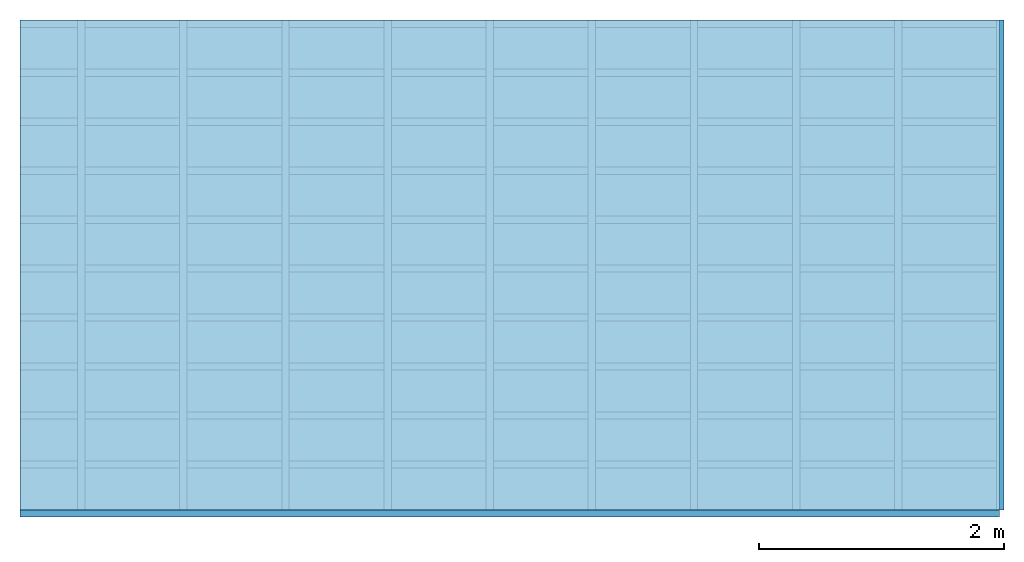
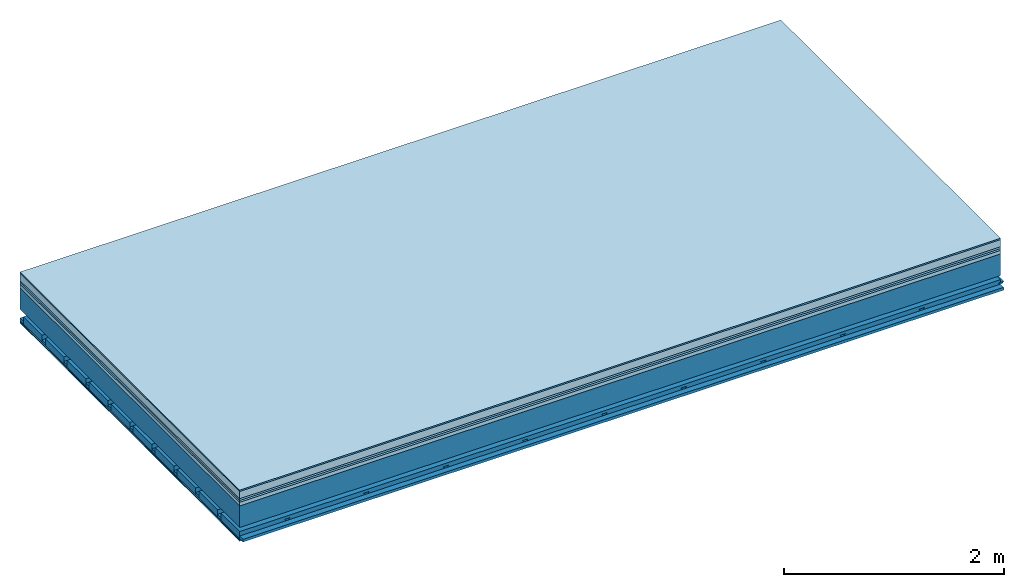
# One storey: 8 plates, 4 members, 1 element without a shape of its own.
"""IFC4 building model written with IfcOpenShell, lengths in metres."""

from ifc_helpers import new_model, si_unit, derived_unit, direction, frame, frame_2d, origin, origin_with_axes, place, context, project, spatial, polyline, rectangle, outline, extrude, material, layer, layer_set, type_object, element, aggregate, save


model = new_model("IFC4")

# Units and contexts
plan_context = context("Plan", 3, precision=1e-05, world=origin(), true_north=direction((0.0, 1.0)))
model_context = context("Model", 3, precision=1e-05, world=origin(), true_north=direction((0.0, 1.0)))
ifc_project = project(units=[si_unit("LENGTHUNIT", "METRE"), derived_unit("SOUNDPRESSUREUNIT", [(si_unit("PRESSUREUNIT", "PASCAL", prefix="MICRO"), 0)]), si_unit("ENERGYUNIT", "JOULE", prefix="MEGA"), si_unit("MASSUNIT", "GRAM", prefix="KILO"), derived_unit("THERMALTRANSMITTANCEUNIT", [(si_unit("POWERUNIT", "WATT"), 1), (si_unit("AREAUNIT", "SQUARE_METRE"), -1), (si_unit("THERMODYNAMICTEMPERATUREUNIT", "KELVIN"), -1)]), derived_unit("AREADENSITYUNIT", [(si_unit("MASSUNIT", "GRAM", prefix="KILO"), 1), (si_unit("AREAUNIT", "SQUARE_METRE"), -1)]), derived_unit("USERDEFINED", [(si_unit("ENERGYUNIT", "JOULE", prefix="MEGA"), 1), (si_unit("AREAUNIT", "SQUARE_METRE"), -1)])], contexts=[plan_context, model_context])

# Site, building, storey
site = spatial("IfcSite", under=ifc_project)
building_placement = place(None, origin())
building = spatial("IfcBuilding", under=site, at=building_placement)
storey_placement = place(building_placement, origin())
storey = spatial("IfcBuildingStorey", under=building, at=storey_placement)

# Slab, members, plates
ifc_material_1 = material(Category="11.013")
ifc_layer_1 = layer(ifc_material_1, 0.015, Name="Flooring")
ifc_material_2 = material(Name="Cement screed", Category="04.006")
ifc_layer_2 = layer(ifc_material_2, 0.08, Name="On-material")
ifc_material_3 = material(Name="Wood fiber generic product", Category="10.009")
ifc_layer_3 = layer(ifc_material_3, 0.02, Name="Impact sound insulation")
ifc_material_4 = material(Category="10.004")
ifc_layer_4 = layer(ifc_material_4, 0.02, Name="Additional insulation")
ifc_material_5 = material(Name="Garden plates", Category="02.007")
ifc_layer_5 = layer(ifc_material_5, 0.04, Name="on Supporting structure")
ifc_material_6 = material(Name="no composite action")
ifc_layer_6 = layer(ifc_material_6, 0.0, Name="Bond")
ifc_layer_7 = layer(None, 0.24, Name="Supporting structure")
ifc_layer_8 = layer(ifc_material_6, 0.0, Name="Bond")
ifc_layer_9 = layer(None, 0.095, Name="Coupling")
ifc_layer_10 = layer(None, 0.03, Name="Battens / profiles")
ifc_material_7 = material(Name="Plasterboard type A", Category="03.008")
ifc_layer_11 = layer(ifc_material_7, 0.0125, Name="Ceiling covering 1st layer")
ifc_layer_12 = layer(ifc_material_7, 0.0125, Name="Ceiling covering layer 2")
ifc_material_8 = material(Category="04.001")
ifc_layer_13 = layer(ifc_material_8, 0.003, Name="Surface / treatment")
ifc_layer_set = layer_set([ifc_layer_1, ifc_layer_2, ifc_layer_3, ifc_layer_4, ifc_layer_5, ifc_layer_6, ifc_layer_7, ifc_layer_8, ifc_layer_9, ifc_layer_10, ifc_layer_11, ifc_layer_12, ifc_layer_13])
slab_type = type_object("IfcSlabType", Name="A2174", PredefinedType="NOTDEFINED", material=ifc_layer_set)
slab_placement = place(None, frame((0.0, 0.0, 0.0), z_axis=(0.0, 0.0, -1.0), x_axis=(1.0, 0.0, 0.0)))
slab = element("IfcSlab", 1, at=slab_placement, inside=storey, type_object=slab_type, material=ifc_layer_set, Name="Slab #1")
ifc_material_9 = material(Name="Solid timber panel")
member_1_placement = place(slab_placement, origin())
member_1 = element("IfcMember", 2, at=member_1_placement, material=ifc_material_9, Name="Supporting structure", context=plan_context, shape_type="SweptSolid", body=[
    extrude(rectangle(XDim=1.0, YDim=0.24, at=frame_2d((0.5, 0.12), x_axis=(1.0, 0.0))), frame((0.0, 4.0, 0.175), z_axis=(0.0, -1.0, 0.0), x_axis=(1.0, 0.0, 0.0)), (0.0, 0.0, 1.0), 4.0),
    extrude(rectangle(XDim=1.0, YDim=0.24, at=frame_2d((0.5, 0.12), x_axis=(1.0, 0.0))), frame((1.0, 4.0, 0.175), z_axis=(0.0, -1.0, 0.0), x_axis=(1.0, 0.0, 0.0)), (0.0, 0.0, 1.0), 4.0),
    extrude(rectangle(XDim=1.0, YDim=0.24, at=frame_2d((0.5, 0.12), x_axis=(1.0, 0.0))), frame((2.0, 4.0, 0.175), z_axis=(0.0, -1.0, 0.0), x_axis=(1.0, 0.0, 0.0)), (0.0, 0.0, 1.0), 4.0),
    extrude(rectangle(XDim=1.0, YDim=0.24, at=frame_2d((0.5, 0.12), x_axis=(1.0, 0.0))), frame((3.0, 4.0, 0.175), z_axis=(0.0, -1.0, 0.0), x_axis=(1.0, 0.0, 0.0)), (0.0, 0.0, 1.0), 4.0),
    extrude(rectangle(XDim=1.0, YDim=0.24, at=frame_2d((0.5, 0.12), x_axis=(1.0, 0.0))), frame((4.0, 4.0, 0.175), z_axis=(0.0, -1.0, 0.0), x_axis=(1.0, 0.0, 0.0)), (0.0, 0.0, 1.0), 4.0),
    extrude(rectangle(XDim=1.0, YDim=0.24, at=frame_2d((0.5, 0.12), x_axis=(1.0, 0.0))), frame((5.0, 4.0, 0.175), z_axis=(0.0, -1.0, 0.0), x_axis=(1.0, 0.0, 0.0)), (0.0, 0.0, 1.0), 4.0),
    extrude(rectangle(XDim=1.0, YDim=0.24, at=frame_2d((0.5, 0.12), x_axis=(1.0, 0.0))), frame((6.0, 4.0, 0.175), z_axis=(0.0, -1.0, 0.0), x_axis=(1.0, 0.0, 0.0)), (0.0, 0.0, 1.0), 4.0),
    extrude(rectangle(XDim=1.0, YDim=0.24, at=frame_2d((0.5, 0.12), x_axis=(1.0, 0.0))), frame((7.0, 4.0, 0.175), z_axis=(0.0, -1.0, 0.0), x_axis=(1.0, 0.0, 0.0)), (0.0, 0.0, 1.0), 4.0),
])
ifc_material_10 = material()
member_2_placement = place(slab_placement, origin())
member_2 = element("IfcMember", 3, at=member_2_placement, material=ifc_material_10, Name="Coupling", context=plan_context, shape_type="SweptSolid", body=[
    extrude(outline(polyline([(0.0, 0.0), (0.06, 0.0), (0.04, 0.02), (0.02, 0.02), (0.0, 0.0)])), frame((0.47, 4.0, 0.49), z_axis=(0.0, -1.0, 0.0), x_axis=(1.0, 0.0, 0.0)), (0.0, 0.0, 1.0), 4.0),
    extrude(outline(polyline([(0.0, 0.0), (0.06, 0.0), (0.04, 0.02), (0.02, 0.02), (0.0, 0.0)])), frame((1.304, 4.0, 0.49), z_axis=(0.0, -1.0, 0.0), x_axis=(1.0, 0.0, 0.0)), (0.0, 0.0, 1.0), 4.0),
    extrude(outline(polyline([(0.0, 0.0), (0.06, 0.0), (0.04, 0.02), (0.02, 0.02), (0.0, 0.0)])), frame((2.138, 4.0, 0.49), z_axis=(0.0, -1.0, 0.0), x_axis=(1.0, 0.0, 0.0)), (0.0, 0.0, 1.0), 4.0),
    extrude(outline(polyline([(0.0, 0.0), (0.06, 0.0), (0.04, 0.02), (0.02, 0.02), (0.0, 0.0)])), frame((2.972, 4.0, 0.49), z_axis=(0.0, -1.0, 0.0), x_axis=(1.0, 0.0, 0.0)), (0.0, 0.0, 1.0), 4.0),
    extrude(outline(polyline([(0.0, 0.0), (0.06, 0.0), (0.04, 0.02), (0.02, 0.02), (0.0, 0.0)])), frame((3.806, 4.0, 0.49), z_axis=(0.0, -1.0, 0.0), x_axis=(1.0, 0.0, 0.0)), (0.0, 0.0, 1.0), 4.0),
    extrude(outline(polyline([(0.0, 0.0), (0.06, 0.0), (0.04, 0.02), (0.02, 0.02), (0.0, 0.0)])), frame((4.64, 4.0, 0.49), z_axis=(0.0, -1.0, 0.0), x_axis=(1.0, 0.0, 0.0)), (0.0, 0.0, 1.0), 4.0),
    extrude(outline(polyline([(0.0, 0.0), (0.06, 0.0), (0.04, 0.02), (0.02, 0.02), (0.0, 0.0)])), frame((5.474, 4.0, 0.49), z_axis=(0.0, -1.0, 0.0), x_axis=(1.0, 0.0, 0.0)), (0.0, 0.0, 1.0), 4.0),
    extrude(outline(polyline([(0.0, 0.0), (0.06, 0.0), (0.04, 0.02), (0.02, 0.02), (0.0, 0.0)])), frame((6.308, 4.0, 0.49), z_axis=(0.0, -1.0, 0.0), x_axis=(1.0, 0.0, 0.0)), (0.0, 0.0, 1.0), 4.0),
    extrude(outline(polyline([(0.0, 0.0), (0.06, 0.0), (0.04, 0.02), (0.02, 0.02), (0.0, 0.0)])), frame((7.142, 4.0, 0.49), z_axis=(0.0, -1.0, 0.0), x_axis=(1.0, 0.0, 0.0)), (0.0, 0.0, 1.0), 4.0),
    extrude(outline(polyline([(0.0, 0.0), (0.06, 0.0), (0.04, 0.02), (0.02, 0.02), (0.0, 0.0)])), frame((7.976, 4.0, 0.49), z_axis=(0.0, -1.0, 0.0), x_axis=(1.0, 0.0, 0.0)), (0.0, 0.0, 1.0), 4.0),
])
member_3_placement = place(slab_placement, origin())
member_3 = element("IfcMember", 4, at=member_3_placement, material=ifc_material_10, Name="Battens / profiles", context=plan_context, shape_type="SweptSolid", body=[
    extrude(rectangle(XDim=0.06, YDim=0.03, at=frame_2d((0.03, 0.015), x_axis=(1.0, 0.0))), frame((0.0, 0.0, 0.51), z_axis=(1.0, 0.0, 0.0), x_axis=(0.0, 1.0, 0.0)), (0.0, 0.0, 1.0), 8.0),
    extrude(rectangle(XDim=0.06, YDim=0.03, at=frame_2d((0.03, 0.015), x_axis=(1.0, 0.0))), frame((0.0, 0.4, 0.51), z_axis=(1.0, 0.0, 0.0), x_axis=(0.0, 1.0, 0.0)), (0.0, 0.0, 1.0), 8.0),
    extrude(rectangle(XDim=0.06, YDim=0.03, at=frame_2d((0.03, 0.015), x_axis=(1.0, 0.0))), frame((0.0, 0.8, 0.51), z_axis=(1.0, 0.0, 0.0), x_axis=(0.0, 1.0, 0.0)), (0.0, 0.0, 1.0), 8.0),
    extrude(rectangle(XDim=0.06, YDim=0.03, at=frame_2d((0.03, 0.015), x_axis=(1.0, 0.0))), frame((0.0, 1.2, 0.51), z_axis=(1.0, 0.0, 0.0), x_axis=(0.0, 1.0, 0.0)), (0.0, 0.0, 1.0), 8.0),
    extrude(rectangle(XDim=0.06, YDim=0.03, at=frame_2d((0.03, 0.015), x_axis=(1.0, 0.0))), frame((0.0, 1.6, 0.51), z_axis=(1.0, 0.0, 0.0), x_axis=(0.0, 1.0, 0.0)), (0.0, 0.0, 1.0), 8.0),
    extrude(rectangle(XDim=0.06, YDim=0.03, at=frame_2d((0.03, 0.015), x_axis=(1.0, 0.0))), frame((0.0, 2.0, 0.51), z_axis=(1.0, 0.0, 0.0), x_axis=(0.0, 1.0, 0.0)), (0.0, 0.0, 1.0), 8.0),
    extrude(rectangle(XDim=0.06, YDim=0.03, at=frame_2d((0.03, 0.015), x_axis=(1.0, 0.0))), frame((0.0, 2.4, 0.51), z_axis=(1.0, 0.0, 0.0), x_axis=(0.0, 1.0, 0.0)), (0.0, 0.0, 1.0), 8.0),
    extrude(rectangle(XDim=0.06, YDim=0.03, at=frame_2d((0.03, 0.015), x_axis=(1.0, 0.0))), frame((0.0, 2.8, 0.51), z_axis=(1.0, 0.0, 0.0), x_axis=(0.0, 1.0, 0.0)), (0.0, 0.0, 1.0), 8.0),
    extrude(rectangle(XDim=0.06, YDim=0.03, at=frame_2d((0.03, 0.015), x_axis=(1.0, 0.0))), frame((0.0, 3.2, 0.51), z_axis=(1.0, 0.0, 0.0), x_axis=(0.0, 1.0, 0.0)), (0.0, 0.0, 1.0), 8.0),
    extrude(rectangle(XDim=0.06, YDim=0.03, at=frame_2d((0.03, 0.015), x_axis=(1.0, 0.0))), frame((0.0, 3.6, 0.51), z_axis=(1.0, 0.0, 0.0), x_axis=(0.0, 1.0, 0.0)), (0.0, 0.0, 1.0), 8.0),
    extrude(rectangle(XDim=0.06, YDim=0.03, at=frame_2d((0.03, 0.015), x_axis=(1.0, 0.0))), frame((0.0, 4.0, 0.51), z_axis=(1.0, 0.0, 0.0), x_axis=(0.0, 1.0, 0.0)), (0.0, 0.0, 1.0), 8.0),
])
ifc_material_11 = material()
member_4_placement = place(slab_placement, origin())
member_4 = element("IfcMember", 5, at=member_4_placement, material=ifc_material_11, Name="Cavity", context=plan_context, shape_type="SweptSolid", body=[
    extrude(rectangle(XDim=0.34, YDim=0.08, at=frame_2d((0.17, 0.04), x_axis=(1.0, 0.0))), frame((0.0, 0.06, 0.46), z_axis=(1.0, 0.0, 0.0), x_axis=(0.0, 1.0, 0.0)), (0.0, 0.0, 1.0), 8.0),
    extrude(rectangle(XDim=0.34, YDim=0.08, at=frame_2d((0.17, 0.04), x_axis=(1.0, 0.0))), frame((0.0, 0.46, 0.46), z_axis=(1.0, 0.0, 0.0), x_axis=(0.0, 1.0, 0.0)), (0.0, 0.0, 1.0), 8.0),
    extrude(rectangle(XDim=0.34, YDim=0.08, at=frame_2d((0.17, 0.04), x_axis=(1.0, 0.0))), frame((0.0, 0.86, 0.46), z_axis=(1.0, 0.0, 0.0), x_axis=(0.0, 1.0, 0.0)), (0.0, 0.0, 1.0), 8.0),
    extrude(rectangle(XDim=0.34, YDim=0.08, at=frame_2d((0.17, 0.04), x_axis=(1.0, 0.0))), frame((0.0, 1.26, 0.46), z_axis=(1.0, 0.0, 0.0), x_axis=(0.0, 1.0, 0.0)), (0.0, 0.0, 1.0), 8.0),
    extrude(rectangle(XDim=0.34, YDim=0.08, at=frame_2d((0.17, 0.04), x_axis=(1.0, 0.0))), frame((0.0, 1.66, 0.46), z_axis=(1.0, 0.0, 0.0), x_axis=(0.0, 1.0, 0.0)), (0.0, 0.0, 1.0), 8.0),
    extrude(rectangle(XDim=0.34, YDim=0.08, at=frame_2d((0.17, 0.04), x_axis=(1.0, 0.0))), frame((0.0, 2.06, 0.46), z_axis=(1.0, 0.0, 0.0), x_axis=(0.0, 1.0, 0.0)), (0.0, 0.0, 1.0), 8.0),
    extrude(rectangle(XDim=0.34, YDim=0.08, at=frame_2d((0.17, 0.04), x_axis=(1.0, 0.0))), frame((0.0, 2.46, 0.46), z_axis=(1.0, 0.0, 0.0), x_axis=(0.0, 1.0, 0.0)), (0.0, 0.0, 1.0), 8.0),
    extrude(rectangle(XDim=0.34, YDim=0.08, at=frame_2d((0.17, 0.04), x_axis=(1.0, 0.0))), frame((0.0, 2.86, 0.46), z_axis=(1.0, 0.0, 0.0), x_axis=(0.0, 1.0, 0.0)), (0.0, 0.0, 1.0), 8.0),
    extrude(rectangle(XDim=0.34, YDim=0.08, at=frame_2d((0.17, 0.04), x_axis=(1.0, 0.0))), frame((0.0, 3.26, 0.46), z_axis=(1.0, 0.0, 0.0), x_axis=(0.0, 1.0, 0.0)), (0.0, 0.0, 1.0), 8.0),
    extrude(rectangle(XDim=0.34, YDim=0.08, at=frame_2d((0.17, 0.04), x_axis=(1.0, 0.0))), frame((0.0, 3.66, 0.46), z_axis=(1.0, 0.0, 0.0), x_axis=(0.0, 1.0, 0.0)), (0.0, 0.0, 1.0), 8.0),
])
plate_1_placement = place(slab_placement, origin())
plate_1 = element("IfcPlate", 6, at=plate_1_placement, material=ifc_material_1, Name="Flooring", context=plan_context, shape_type="SweptSolid", body=[
    extrude(rectangle(XDim=8.0, YDim=4.0, at=frame_2d((4.0, 2.0), x_axis=(1.0, 0.0))), origin_with_axes(), (0.0, 0.0, 1.0), 0.015),
])
plate_2_placement = place(slab_placement, origin())
plate_2 = element("IfcPlate", 7, at=plate_2_placement, material=ifc_material_2, Name="On-material", context=plan_context, shape_type="SweptSolid", body=[
    extrude(rectangle(XDim=8.0, YDim=4.0, at=frame_2d((4.0, 2.0), x_axis=(1.0, 0.0))), frame((0.0, 0.0, 0.015), z_axis=(0.0, 0.0, 1.0), x_axis=(1.0, 0.0, 0.0)), (0.0, 0.0, 1.0), 0.08),
])
plate_3_placement = place(slab_placement, origin())
plate_3 = element("IfcPlate", 8, at=plate_3_placement, material=ifc_material_3, Name="Impact sound insulation", context=plan_context, shape_type="SweptSolid", body=[
    extrude(rectangle(XDim=8.0, YDim=4.0, at=frame_2d((4.0, 2.0), x_axis=(1.0, 0.0))), frame((0.0, 0.0, 0.095), z_axis=(0.0, 0.0, 1.0), x_axis=(1.0, 0.0, 0.0)), (0.0, 0.0, 1.0), 0.02),
])
plate_4_placement = place(slab_placement, origin())
plate_4 = element("IfcPlate", 9, at=plate_4_placement, material=ifc_material_4, Name="Additional insulation", context=plan_context, shape_type="SweptSolid", body=[
    extrude(rectangle(XDim=8.0, YDim=4.0, at=frame_2d((4.0, 2.0), x_axis=(1.0, 0.0))), frame((0.0, 0.0, 0.115), z_axis=(0.0, 0.0, 1.0), x_axis=(1.0, 0.0, 0.0)), (0.0, 0.0, 1.0), 0.02),
])
plate_5_placement = place(slab_placement, origin())
plate_5 = element("IfcPlate", 10, at=plate_5_placement, material=ifc_material_5, Name="on Supporting structure", context=plan_context, shape_type="SweptSolid", body=[
    extrude(rectangle(XDim=8.0, YDim=4.0, at=frame_2d((4.0, 2.0), x_axis=(1.0, 0.0))), frame((0.0, 0.0, 0.135), z_axis=(0.0, 0.0, 1.0), x_axis=(1.0, 0.0, 0.0)), (0.0, 0.0, 1.0), 0.04),
])
plate_6_placement = place(slab_placement, origin())
plate_6 = element("IfcPlate", 11, at=plate_6_placement, material=ifc_material_7, Name="Ceiling covering 1st layer", context=plan_context, shape_type="SweptSolid", body=[
    extrude(rectangle(XDim=8.0, YDim=4.0, at=frame_2d((4.0, 2.0), x_axis=(1.0, 0.0))), frame((0.0, 0.0, 0.54), z_axis=(0.0, 0.0, 1.0), x_axis=(1.0, 0.0, 0.0)), (0.0, 0.0, 1.0), 0.0125),
])
plate_7_placement = place(slab_placement, origin())
plate_7 = element("IfcPlate", 12, at=plate_7_placement, material=ifc_material_7, Name="Ceiling covering layer 2", context=plan_context, shape_type="SweptSolid", body=[
    extrude(rectangle(XDim=8.0, YDim=4.0, at=frame_2d((4.0, 2.0), x_axis=(1.0, 0.0))), frame((0.0, 0.0, 0.5525), z_axis=(0.0, 0.0, 1.0), x_axis=(1.0, 0.0, 0.0)), (0.0, 0.0, 1.0), 0.0125),
])
plate_8_placement = place(slab_placement, origin())
plate_8 = element("IfcPlate", 13, at=plate_8_placement, material=ifc_material_8, Name="Surface / treatment", context=plan_context, shape_type="SweptSolid", body=[
    extrude(rectangle(XDim=8.0, YDim=4.0, at=frame_2d((4.0, 2.0), x_axis=(1.0, 0.0))), frame((0.0, 0.0, 0.565), z_axis=(0.0, 0.0, 1.0), x_axis=(1.0, 0.0, 0.0)), (0.0, 0.0, 1.0), 0.003),
])
aggregate(slab, [plate_1, plate_2, plate_3, plate_4, plate_5, member_1, member_2, member_3, member_4, plate_6, plate_7, plate_8])

save(model, "model.ifc")
